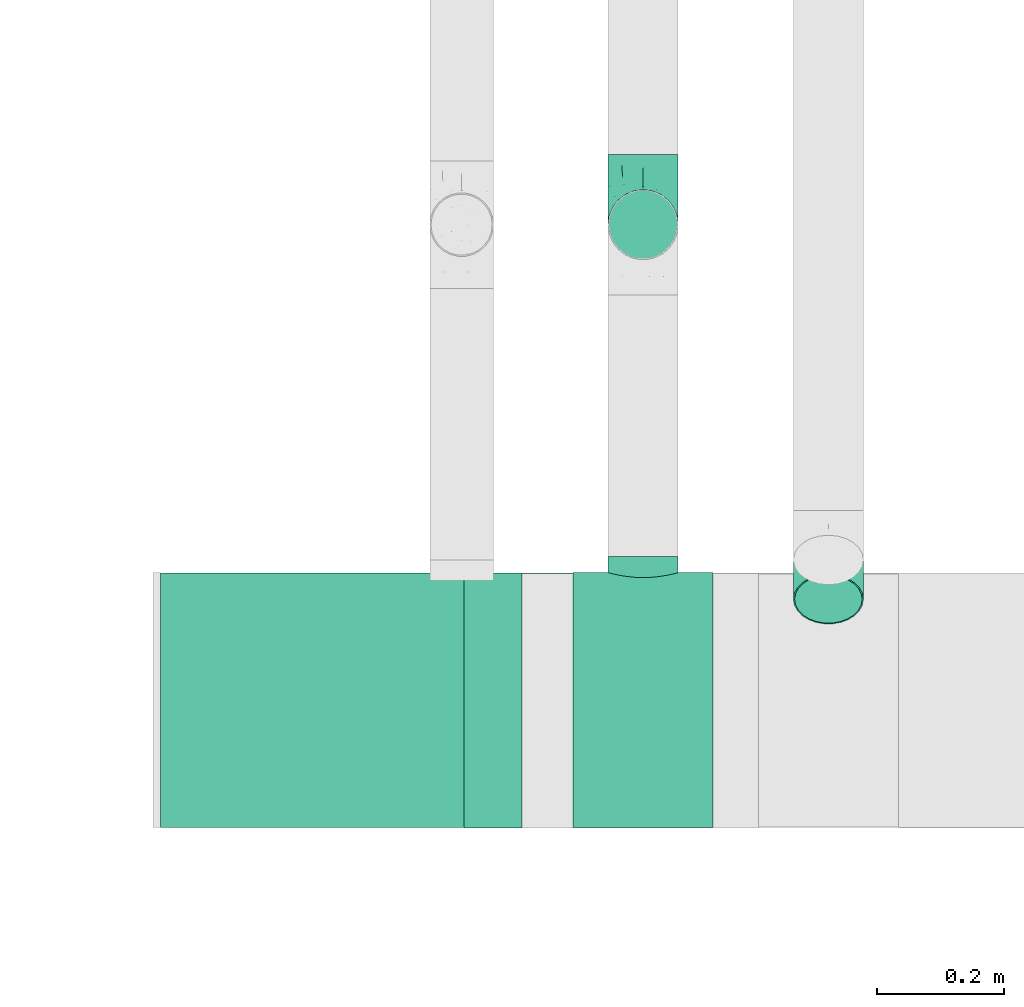
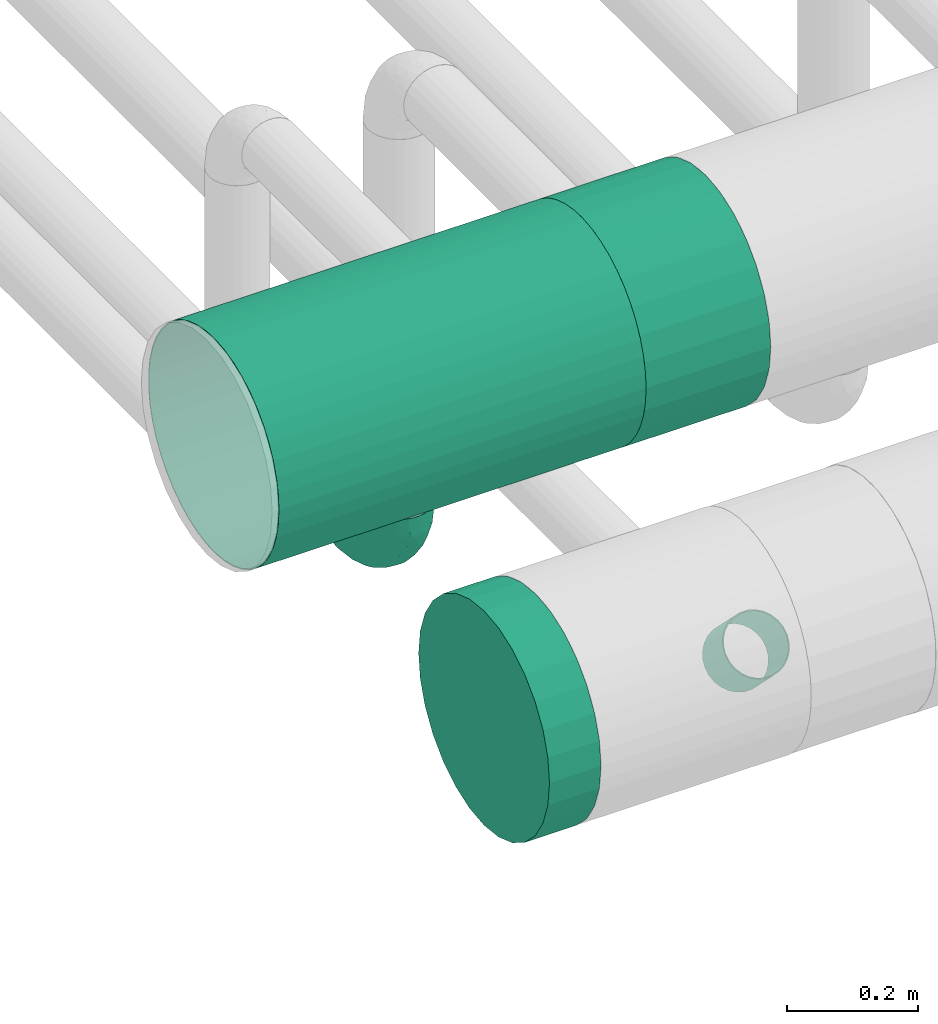
# One storey, part 73 of 91: 3 flow fittings, 2 flow segments.
"""IFC2X3 building model written with IfcOpenShell, lengths in millimetres."""

from ifc_helpers import new_model, entity, si_unit, converted_unit, derived_unit, direction, frame, origin_with_axes, origin_2d_with_axis, place, context, subcontext, project, spatial, hollow_circle, extrude, open_shell, surface_model, source, transform, mapped, material, layer, layer_set, layer_usage, type_object, element, save


model = new_model("IFC2X3")

# Units and contexts
model_context = context("Model", 3, precision=1e-05, world=origin_with_axes(), true_north=direction((0.0, 1.0)))
body_context = subcontext(model_context, "Body", "Model", "MODEL_VIEW")
ifc_project = project(units=[si_unit("AREAUNIT", "SQUARE_METRE"), si_unit("VOLUMEUNIT", "CUBIC_METRE", prefix="DECI"), si_unit("TIMEUNIT", "SECOND"), si_unit("THERMODYNAMICTEMPERATUREUNIT", "DEGREE_CELSIUS"), si_unit("PRESSUREUNIT", "PASCAL"), si_unit("MASSUNIT", "GRAM", prefix="KILO"), si_unit("LENGTHUNIT", "METRE", prefix="MILLI"), si_unit("POWERUNIT", "WATT"), si_unit("ELECTRICCURRENTUNIT", "AMPERE"), si_unit("ELECTRICVOLTAGEUNIT", "VOLT"), derived_unit("VOLUMETRICFLOWRATEUNIT", [(si_unit("VOLUMEUNIT", "CUBIC_METRE", prefix="DECI"), 1), (si_unit("TIMEUNIT", "SECOND"), -1)]), derived_unit("LINEARVELOCITYUNIT", [(si_unit("LENGTHUNIT", "METRE"), 1), (si_unit("TIMEUNIT", "SECOND"), -1)]), derived_unit("MASSDENSITYUNIT", [(si_unit("MASSUNIT", "GRAM", prefix="KILO"), 1), (si_unit("VOLUMEUNIT", "CUBIC_METRE"), -1)]), converted_unit("PLANEANGLEUNIT", "DEGREE", entity("IfcRatioMeasure", 0.01745), si_unit("PLANEANGLEUNIT", "RADIAN"), dimensions=[0, 0, 0, 0, 0, 0, 0])], contexts=[model_context])

# Site, building, storey
site_placement = place(None, origin_with_axes())
site = spatial("IfcSite", under=ifc_project, at=site_placement, CompositionType="ELEMENT")
building_placement = place(site_placement, origin_with_axes())
building = spatial("IfcBuilding", under=site, at=building_placement, Name="mc-building", CompositionType="ELEMENT")
storey_placement = place(building_placement, frame((0.0, 0.0, 8700.0), z_axis=(0.0, 0.0, 1.0), x_axis=(1.0, 0.0, 0.0)))
storey = spatial("IfcBuildingStorey", under=building, at=storey_placement, CompositionType="ELEMENT", Elevation=8700.0)

# Flow fittings
duct_fitting_type_1 = type_object("IfcDuctFittingType", PredefinedType="JUNCTION")
shared_shape_1 = source(origin_with_axes(), body_context, "Body", "SurfaceModel", [
    surface_model("IfcShellBasedSurfaceModel", [(0.0, -225.0, -55.0), (14.23505, -225.0, -53.12592), (-14.23505, -225.0, -53.12592), (-53.12592, -225.0, 14.23505), (-27.5, -225.0, -47.63139), (-47.63139, -225.0, -27.5), (-38.89087, -225.0, -38.89087), (55.0, -225.0, 0.0), (53.12592, -225.0, 14.23505), (38.89087, -225.0, -38.89087), (27.5, -225.0, -47.63139), (53.12592, -225.0, -14.23505), (47.63139, -225.0, -27.5), (-53.12592, -225.0, -14.23505), (-47.63139, -225.0, 27.5), (-38.89087, -225.0, 38.89087), (14.23505, -225.0, 53.12592), (-27.5, -225.0, 47.63139), (-14.23505, -225.0, 53.12592), (47.63139, -225.0, 27.5), (38.89087, -225.0, 38.89087), (27.5, -225.0, 47.63139), (0.0, -225.0, 55.0), (-55.0, -225.0, 0.0), (0.0, -192.28884, 55.0), (-12.29394, -192.68144, 53.60839), (-23.92751, -193.77184, 49.52246), (-34.31923, -195.32745, 42.97895), (-42.9874, -197.03532, 34.30865), (-49.52973, -198.56533, 23.91246), (-53.61252, -199.6229, 12.27592), (-55.0, -200.0, 0.0), (-49.52091, -198.56313, -23.93071), (-42.97449, -197.0325, -34.32482), (-53.60826, -199.62175, -12.29447), (-34.30293, -195.32458, -42.99196), (-23.90904, -193.76957, -49.53138), (-12.27509, -192.68024, -53.61271), (0.0, -192.28884, -55.0), (12.29394, -192.68144, -53.60839), (23.92751, -193.77184, -49.52246), (34.31923, -195.32745, -42.97895), (42.9874, -197.03532, -34.30865), (49.52973, -198.56533, -23.91246), (53.61252, -199.6229, -12.27592), (55.0, -200.0, 0.0), (49.52973, -198.56533, 23.91246), (42.9874, -197.03532, 34.30865), (53.61252, -199.6229, 12.27592), (34.31923, -195.32745, 42.97895), (23.92751, -193.77184, 49.52246), (12.29394, -192.68144, 53.60839), (-110.0, 0.0, -200.0), (-110.0, -44.50419, -194.98559), (-110.0, 44.50419, -194.98559), (-110.0, 194.98559, 44.50419), (-110.0, 86.77674, -180.19378), (-110.0, 180.19378, -86.77674), (-110.0, 156.36629, -124.69796), (-110.0, 124.69796, -156.36629), (-110.0, -200.0, 0.0), (-110.0, -194.98559, 44.50419), (-110.0, -124.69796, -156.36629), (-110.0, -86.77674, -180.19378), (-110.0, -156.36629, -124.69796), (-110.0, -180.19378, -86.77674), (-110.0, -194.98559, -44.50419), (-110.0, 194.98559, -44.50419), (-110.0, 180.19378, 86.77674), (-110.0, 156.36629, 124.69796), (-110.0, 86.77674, 180.19378), (-110.0, 124.69796, 156.36629), (-110.0, 44.50419, 194.98559), (-110.0, 0.0, 200.0), (-110.0, -156.36629, 124.69796), (-110.0, -180.19378, 86.77674), (-110.0, -86.77674, 180.19378), (-110.0, -44.50419, 194.98559), (-110.0, -124.69796, 156.36629), (-110.0, 200.0, 0.0), (110.0, 0.0, -200.0), (110.0, 44.50419, -194.98559), (110.0, 86.77674, -180.19378), (110.0, 200.0, 0.0), (110.0, 156.36629, -124.69796), (110.0, 180.19378, -86.77674), (110.0, 124.69796, -156.36629), (110.0, -156.36629, -124.69796), (110.0, -194.98559, 44.50419), (110.0, -86.77674, -180.19378), (110.0, -44.50419, -194.98559), (110.0, -124.69796, -156.36629), (110.0, -180.19378, -86.77674), (110.0, -194.98559, -44.50419), (110.0, -200.0, 0.0), (110.0, 194.98559, -44.50419), (110.0, 194.98559, 44.50419), (110.0, 180.19378, 86.77674), (110.0, 156.36629, 124.69796), (110.0, 124.69796, 156.36629), (110.0, 86.77674, 180.19378), (110.0, 44.50419, 194.98559), (110.0, -156.36629, 124.69796), (110.0, -180.19378, 86.77674), (110.0, -124.69796, 156.36629), (110.0, -86.77674, 180.19378), (110.0, -44.50419, 194.98559), (110.0, 0.0, 200.0), (-110.0, -197.4928, -22.25209), (110.0, -197.4928, -22.25209), (110.0, -197.4928, 22.25209), (-110.0, -197.4928, 22.25209)], [open_shell([[[0, 1, 2]], [[2, 3, 4]], [[5, 6, 3]], [[6, 4, 3]], [[2, 7, 8]], [[9, 7, 10]], [[1, 10, 7]], [[11, 7, 12]], [[9, 12, 7]], [[7, 2, 1]], [[5, 3, 13]], [[2, 14, 3]], [[2, 15, 14]], [[2, 16, 17]], [[17, 15, 2]], [[16, 18, 17]], [[2, 8, 19]], [[2, 19, 20]], [[2, 20, 21]], [[16, 2, 21]], [[16, 22, 18]], [[23, 13, 3]], [[22, 24, 25]], [[18, 25, 26]], [[22, 25, 18]], [[17, 27, 15]], [[17, 18, 26]], [[27, 17, 26]], [[28, 29, 14]], [[30, 31, 23]], [[29, 30, 3]], [[15, 28, 14]], [[3, 14, 29]], [[23, 3, 30]], [[28, 15, 27]], [[32, 33, 5]], [[34, 32, 13]], [[31, 34, 23]], [[23, 34, 13]], [[32, 5, 13]], [[33, 6, 5]], [[4, 35, 36]], [[36, 37, 2]], [[38, 0, 37]], [[4, 6, 35]], [[2, 4, 36]], [[37, 0, 2]], [[35, 6, 33]], [[0, 38, 39]], [[1, 39, 40]], [[0, 39, 1]], [[10, 41, 9]], [[10, 1, 40]], [[41, 10, 40]], [[42, 43, 12]], [[44, 45, 7]], [[43, 44, 11]], [[9, 42, 12]], [[11, 12, 43]], [[7, 11, 44]], [[42, 9, 41]], [[46, 47, 19]], [[48, 46, 8]], [[45, 48, 7]], [[7, 48, 8]], [[46, 19, 8]], [[47, 20, 19]], [[21, 49, 50]], [[50, 51, 16]], [[24, 22, 51]], [[20, 49, 21]], [[16, 21, 50]], [[22, 16, 51]], [[49, 20, 47]], [[52, 53, 54]], [[54, 55, 56]], [[55, 57, 58]], [[58, 59, 55]], [[59, 56, 55]], [[54, 60, 61]], [[62, 60, 63]], [[54, 53, 63]], [[60, 64, 65]], [[65, 66, 60]], [[60, 62, 64]], [[63, 60, 54]], [[55, 67, 57]], [[54, 68, 55]], [[54, 69, 68]], [[70, 71, 69]], [[70, 54, 72]], [[70, 69, 54]], [[72, 54, 73]], [[74, 73, 75]], [[54, 61, 75]], [[76, 77, 73]], [[73, 78, 76]], [[74, 78, 73]], [[54, 75, 73]], [[79, 67, 55]], [[80, 81, 82]], [[83, 80, 82]], [[84, 85, 83]], [[83, 86, 84]], [[83, 82, 86]], [[87, 80, 88]], [[80, 89, 90]], [[80, 91, 89]], [[91, 80, 87]], [[87, 88, 92]], [[93, 92, 88]], [[93, 88, 94]], [[85, 95, 83]], [[83, 96, 97]], [[98, 80, 97]], [[98, 99, 100]], [[80, 100, 101]], [[80, 98, 100]], [[80, 101, 102]], [[102, 103, 80]], [[88, 80, 103]], [[104, 102, 101]], [[104, 101, 105]], [[101, 106, 105]], [[101, 107, 106]], [[83, 97, 80]], [[72, 107, 101]], [[70, 101, 100]], [[71, 100, 99]], [[73, 107, 72]], [[72, 101, 70]], [[100, 71, 70]], [[99, 69, 71]], [[68, 98, 97]], [[55, 97, 96]], [[79, 96, 83]], [[69, 98, 68]], [[68, 97, 55]], [[96, 79, 55]], [[98, 69, 99]], [[83, 95, 79]], [[85, 84, 58]], [[95, 85, 67]], [[67, 79, 95]], [[58, 57, 85]], [[67, 85, 57]], [[84, 59, 58]], [[56, 86, 82]], [[54, 82, 81]], [[52, 81, 80]], [[59, 86, 56]], [[56, 82, 54]], [[81, 52, 54]], [[86, 59, 84]], [[90, 53, 80]], [[89, 63, 90]], [[65, 87, 92]], [[89, 91, 62]], [[87, 64, 91]], [[92, 40, 39]], [[39, 38, 92]], [[53, 90, 63]], [[62, 63, 89]], [[53, 52, 80]], [[38, 37, 65]], [[34, 108, 32]], [[64, 87, 65]], [[37, 36, 65]], [[64, 62, 91]], [[38, 65, 92]], [[42, 109, 43]], [[93, 42, 41]], [[93, 109, 42]], [[41, 40, 93]], [[93, 40, 92]], [[94, 45, 44]], [[43, 109, 44]], [[44, 109, 94]], [[36, 35, 66]], [[33, 32, 108]], [[33, 66, 35]], [[36, 66, 65]], [[34, 60, 108]], [[31, 60, 34]], [[108, 66, 33]], [[45, 94, 48]], [[94, 110, 48]], [[110, 47, 46]], [[47, 110, 88]], [[49, 47, 88]], [[29, 111, 30]], [[60, 31, 30]], [[111, 60, 30]], [[27, 26, 61]], [[61, 111, 28]], [[61, 28, 27]], [[26, 75, 61]], [[49, 88, 50]], [[51, 103, 24]], [[48, 110, 46]], [[51, 50, 103]], [[74, 103, 102]], [[103, 50, 88]], [[105, 106, 77]], [[76, 104, 105]], [[78, 102, 104]], [[73, 106, 107]], [[25, 24, 75]], [[28, 111, 29]], [[75, 24, 103]], [[74, 75, 103]], [[25, 75, 26]], [[102, 78, 74]], [[104, 76, 78]], [[77, 76, 105]], [[106, 73, 77]]])]),
])
flow_fitting_1_placement = place(storey_placement, frame((29597.94843, 10080.96985, 1344.0), z_axis=(0.0, 0.0, 1.0), x_axis=(-1.0, 0.0, 0.0)))
element("IfcFlowFitting", 1, at=flow_fitting_1_placement, inside=storey, type_object=duct_fitting_type_1, context=body_context, shape_type="MappedRepresentation", body=[
    mapped(shared_shape_1, transform((0.0, 0.0, 0.0), scale=1.0)),
])
duct_fitting_type_2 = type_object("IfcDuctFittingType", Name="BU", PredefinedType="BEND")
shared_shape_2 = source(origin_with_axes(), body_context, "Body", "SurfaceModel", [
    surface_model("IfcShellBasedSurfaceModel", [(-110.0, 0.0, -55.0), (-110.0, -14.23505, -53.12592), (-110.0, 14.23505, -53.12592), (-110.0, 53.12592, 14.23505), (-110.0, 27.5, -47.63139), (-110.0, 38.89087, -38.89087), (-110.0, -55.0, 0.0), (-110.0, -53.12592, 14.23505), (-110.0, -38.89087, -38.89087), (-110.0, -27.5, -47.63139), (-110.0, -53.12592, -14.23505), (-110.0, -47.63139, -27.5), (-110.0, -14.23505, 53.12592), (-110.0, 14.23505, 53.12592), (-110.0, 27.5, 47.63139), (-110.0, -47.63139, 27.5), (-110.0, -38.89087, 38.89087), (-110.0, -27.5, 47.63139), (-110.0, 0.0, 55.0), (-110.0, 55.0, 0.0), (-110.0, 53.12592, -14.23505), (-110.0, 47.63139, -27.5), (-110.0, 47.63139, 27.5), (-110.0, 38.89087, 38.89087), (-14.23505, 110.0, -53.12592), (-55.0, 110.0, 0.0), (0.0, 110.0, -55.0), (-27.5, 110.0, -47.63139), (-38.89087, 110.0, -38.89087), (-47.63139, 110.0, -27.5), (38.89087, 110.0, -38.89087), (53.12592, 110.0, 14.23505), (27.5, 110.0, -47.63139), (14.23505, 110.0, -53.12592), (47.63139, 110.0, -27.5), (53.12592, 110.0, -14.23505), (55.0, 110.0, 0.0), (-53.12592, 110.0, -14.23505), (-53.12592, 110.0, 14.23505), (-47.63139, 110.0, 27.5), (-38.89087, 110.0, 38.89087), (-27.5, 110.0, 47.63139), (0.0, 110.0, 55.0), (-14.23505, 110.0, 53.12592), (38.89087, 110.0, 38.89087), (47.63139, 110.0, 27.5), (27.5, 110.0, 47.63139), (14.23505, 110.0, 53.12592), (-64.21732, 48.68956, 43.63444), (-76.6405, 38.18013, 45.55988), (-60.44912, 32.56953, 51.94617), (-76.00813, 5.38378, 55.0), (-90.15553, 11.94394, 54.09138), (-78.5998, 26.77405, 50.81338), (-70.18771, 18.55163, 54.03432), (-75.55424, 54.2118, 32.41257), (-93.27622, 45.77614, 33.48188), (-96.12334, 22.13664, 50.81337), (-21.00813, 45.34362, 55.0), (-18.36258, 70.48427, 54.04484), (-32.04182, 59.64019, 52.24446), (-63.88653, 74.77858, 17.99134), (-74.66383, 63.08407, 19.92123), (-63.60674, 66.07878, 29.97482), (-99.597, 52.72185, 18.52927), (-93.11138, 56.59448, 10.50359), (-98.21577, 57.34403, 0.0), (-53.42855, 92.60092, 21.04759), (-88.54852, 54.8376, 21.04759), (-11.86161, 90.23965, 54.10313), (-5.38378, 76.00813, 55.0), (-57.34403, 98.21577, 0.0), (-56.64619, 93.12774, 10.22088), (-45.34362, 21.00813, 55.0), (-44.60838, 44.60838, 52.13415), (-92.68484, 35.46673, 43.63443), (-22.25266, 95.40765, 50.81337), (-35.97783, 90.61597, 43.63443), (-43.70931, 69.58671, 44.47149), (-27.23711, 77.39884, 50.81337), (-57.2828, 79.3123, 24.9774), (-58.67786, 84.31125, 16.04456), (-82.93277, 60.36161, 12.91784), (-49.88337, 54.51816, 47.224), (-74.57753, 66.83759, 9.55742), (-45.35812, 94.97281, 33.48188), (-59.18663, 88.95241, 0.0), (-51.517, 78.6292, 33.48188), (-65.14788, 80.03077, 0.0), (-56.45322, 62.06476, 39.63545), (-88.95241, 59.18663, 0.0), (-71.10913, 71.10913, 0.0), (-80.03077, 65.14788, 0.0), (-94.9309, 45.36788, -33.48188), (-93.11358, 56.60141, -10.46614), (-99.64997, 52.79499, -18.30015), (-90.20425, 36.08686, -43.63443), (-79.99933, 46.56772, -37.92748), (-76.00813, 5.38378, -55.0), (-72.75364, 19.68651, -53.60527), (-45.34362, 21.00813, -55.0), (-21.91957, 65.12078, -53.85897), (-5.38378, 76.00813, -55.0), (-21.00813, 45.34362, -55.0), (-35.41876, 92.89265, -43.63443), (-91.10309, 11.02766, -54.21832), (-45.77614, 93.27622, -33.48188), (-90.50474, 23.21022, -50.81337), (-70.92854, 33.31794, -49.51754), (-78.52933, 63.35627, -11.73997), (-24.91508, 84.05606, -50.81337), (-88.78941, 54.74452, -21.04759), (-69.59921, 57.34866, -33.48187), (-73.36422, 62.46673, -22.94182), (-63.49062, 67.59111, -28.46929), (-56.59448, 93.11138, -10.50359), (-54.8376, 88.54852, -21.04759), (-54.10679, 75.85581, -32.31867), (-57.75956, 31.09612, -52.80882), (-52.72185, 99.597, -18.52927), (-12.62913, 89.46304, -53.99097), (-34.46825, 66.46123, -50.04329), (-43.9837, 43.9837, -52.42279), (-65.78527, 72.58348, -17.68796), (-70.34468, 43.65295, -44.21951), (-57.47001, 51.99467, -44.91465), (-60.72547, 82.29174, -12.88567), (-42.34915, 74.24548, -43.63444), (-57.25194, 63.5016, -38.08211), (-80.95344, 53.56991, -29.32027), (-52.32891, 4.55257, -54.0482), (32.52942, 47.13398, -30.48571), (14.88266, 20.92917, -33.7947), (14.95561, 36.05775, -42.26543), (30.24048, 70.09027, -41.7461), (19.3559, 65.35825, -48.00507), (-70.35075, -46.44478, -19.5952), (-47.13398, -32.52942, -30.48571), (-28.49299, -30.5778, -16.4009), (-4.55257, 52.32891, -54.0482), (-22.4954, 22.4954, -53.25347), (-75.47368, -11.22546, -52.60718), (-81.32209, -51.5606, -9.98467), (-80.81763, -41.84862, -32.14655), (-70.09027, -30.24048, -41.7461), (-36.05774, -14.95561, -42.26543), (-9.15831, -10.852, -27.8997), (-65.35825, -19.3559, -48.00507), (11.22546, 75.47368, -52.60718), (3.94376, 43.9333, -50.53315), (-13.39742, 13.39743, -48.13058), (-43.9333, -3.94376, -50.53315), (49.37776, 67.29486, 0.0), (41.8609, 47.82256, -9.92641), (50.20582, 74.51695, -9.9731), (18.93131, 11.7156, -17.56239), (-27.5, -32.89419, 0.0), (-1.23348, -12.25375, -12.18106), (41.84862, 80.81763, -32.14655), (35.70604, 41.31408, -20.38235), (46.44478, 70.35075, -19.5952), (32.89419, 27.5, 0.0), (6.67262, -6.67262, 0.0), (-67.29486, -49.37776, 0.0), (-50.36265, -42.95545, -9.51562), (-5.47251, 5.47251, -39.92906), (-70.35075, -46.44478, 19.5952), (-74.51695, -50.20582, 9.9731), (-41.31407, -35.70604, 20.38235), (-47.13398, -32.52942, 30.48571), (-80.81763, -41.84862, 32.14655), (-4.55257, 52.32891, 54.0482), (11.22546, 75.47368, 52.60718), (-43.9333, -3.94376, 50.53315), (-65.35825, -19.3559, 48.00507), (-36.05774, -14.95561, 42.26543), (-70.09027, -30.24048, 41.7461), (-11.7156, -18.93131, 17.56239), (30.5778, 28.49299, 16.4009), (12.25375, 1.23348, 12.18106), (51.5606, 81.32209, 9.98467), (42.95545, 50.36265, 9.51562), (-75.47368, -11.22546, 52.60718), (-52.32891, 4.55257, 54.0482), (3.94376, 43.9333, 50.53315), (-22.4954, 22.4954, 53.25347), (-13.39742, 13.39743, 48.13058), (10.852, 9.15831, 27.8997), (-20.92916, -14.88266, 33.79469), (-47.82256, -41.8609, 9.92641), (32.52942, 47.13398, 30.48571), (46.44478, 70.35075, 19.5952), (41.84862, 80.81763, 32.14655), (30.24048, 70.09027, 41.7461), (19.3559, 65.35825, 48.00507), (14.95561, 36.05775, 42.26543), (-5.47251, 5.47251, 39.92906)], [open_shell([[[0, 1, 2]], [[2, 3, 4]], [[4, 3, 5]], [[2, 6, 7]], [[8, 6, 9]], [[1, 9, 6]], [[10, 6, 11]], [[8, 11, 6]], [[6, 2, 1]], [[12, 13, 14]], [[15, 2, 7]], [[16, 17, 2]], [[2, 17, 12]], [[12, 18, 13]], [[19, 20, 3]], [[5, 3, 21]], [[20, 21, 3]], [[22, 3, 2]], [[23, 22, 2]], [[12, 14, 2]], [[2, 14, 23]], [[15, 16, 2]], [[24, 25, 26]], [[27, 25, 24]], [[25, 28, 29]], [[28, 25, 27]], [[30, 26, 31]], [[26, 30, 32]], [[32, 33, 26]], [[34, 31, 35]], [[31, 34, 30]], [[35, 31, 36]], [[29, 37, 25]], [[38, 39, 26]], [[39, 40, 26]], [[41, 42, 40]], [[42, 26, 40]], [[42, 41, 43]], [[26, 44, 45]], [[31, 26, 45]], [[26, 46, 44]], [[47, 46, 26]], [[42, 47, 26]], [[25, 38, 26]], [[48, 49, 50]], [[18, 51, 52]], [[53, 54, 50]], [[55, 56, 49]], [[56, 22, 23]], [[13, 57, 14]], [[58, 59, 60]], [[61, 62, 63]], [[3, 64, 65]], [[53, 52, 54]], [[3, 65, 66]], [[67, 39, 38]], [[56, 68, 64]], [[65, 64, 68]], [[69, 59, 70]], [[38, 71, 72]], [[73, 58, 74]], [[75, 49, 56]], [[76, 69, 43]], [[53, 57, 52]], [[77, 78, 79]], [[41, 76, 43]], [[43, 69, 42]], [[55, 68, 56]], [[23, 14, 75]], [[76, 77, 79]], [[80, 67, 81]], [[62, 82, 68]], [[60, 78, 83]], [[62, 84, 82]], [[85, 77, 40]], [[81, 67, 72]], [[86, 72, 71]], [[87, 85, 67]], [[61, 81, 88]], [[77, 41, 40]], [[78, 77, 87]], [[23, 75, 56]], [[83, 89, 48]], [[85, 40, 39]], [[62, 68, 55]], [[89, 87, 63]], [[83, 48, 50]], [[57, 75, 14]], [[49, 75, 53]], [[67, 85, 39]], [[87, 77, 85]], [[63, 62, 55]], [[89, 55, 48]], [[80, 63, 87]], [[66, 65, 90]], [[66, 19, 3]], [[84, 91, 92]], [[92, 90, 82]], [[65, 82, 90]], [[61, 84, 62]], [[92, 82, 84]], [[68, 82, 65]], [[3, 22, 64]], [[56, 64, 22]], [[38, 25, 71]], [[81, 72, 86]], [[38, 72, 67]], [[91, 61, 88]], [[80, 81, 61]], [[63, 80, 61]], [[67, 80, 87]], [[77, 76, 41]], [[79, 59, 69]], [[79, 69, 76]], [[42, 69, 70]], [[60, 59, 79]], [[58, 70, 59]], [[78, 60, 79]], [[58, 60, 74]], [[52, 57, 13]], [[75, 57, 53]], [[18, 52, 13]], [[52, 51, 54]], [[51, 73, 54]], [[50, 73, 74]], [[73, 50, 54]], [[50, 74, 83]], [[60, 83, 74]], [[89, 83, 78]], [[87, 89, 78]], [[55, 89, 63]], [[50, 49, 53]], [[55, 49, 48]], [[81, 86, 88]], [[91, 84, 61]], [[5, 21, 93]], [[90, 94, 66]], [[20, 94, 95]], [[96, 93, 97]], [[98, 99, 100]], [[96, 4, 5]], [[101, 102, 103]], [[28, 27, 104]], [[2, 105, 0]], [[104, 106, 28]], [[99, 105, 107]], [[108, 107, 96]], [[90, 109, 94]], [[107, 2, 4]], [[20, 66, 94]], [[27, 24, 110]], [[109, 111, 94]], [[112, 113, 114]], [[37, 115, 71]], [[116, 106, 117]], [[99, 118, 100]], [[116, 115, 119]], [[37, 119, 115]], [[24, 120, 110]], [[121, 110, 101]], [[119, 106, 116]], [[101, 110, 120]], [[122, 103, 100]], [[117, 123, 116]], [[124, 125, 108]], [[115, 116, 126]], [[106, 29, 28]], [[26, 102, 120]], [[127, 104, 110]], [[97, 124, 96]], [[125, 122, 118]], [[128, 127, 125]], [[96, 5, 93]], [[115, 126, 86]], [[117, 106, 127]], [[111, 113, 129]], [[95, 93, 21]], [[97, 129, 112]], [[110, 104, 27]], [[106, 104, 127]], [[96, 107, 4]], [[99, 107, 108]], [[99, 108, 118]], [[105, 99, 98]], [[112, 114, 128]], [[121, 125, 127]], [[20, 19, 66]], [[109, 90, 92]], [[94, 111, 95]], [[91, 123, 109]], [[129, 113, 112]], [[93, 95, 111]], [[21, 20, 95]], [[71, 115, 86]], [[71, 25, 37]], [[123, 91, 88]], [[126, 116, 123]], [[123, 88, 126]], [[86, 126, 88]], [[37, 29, 119]], [[106, 119, 29]], [[129, 93, 111]], [[124, 112, 125]], [[0, 105, 98]], [[107, 105, 2]], [[125, 118, 108]], [[100, 118, 122]], [[93, 129, 97]], [[113, 111, 109]], [[109, 123, 113]], [[114, 123, 117]], [[123, 114, 113]], [[128, 114, 117]], [[127, 128, 117]], [[112, 128, 125]], [[103, 122, 101]], [[110, 121, 127]], [[101, 122, 121]], [[125, 121, 122]], [[26, 120, 24]], [[101, 120, 102]], [[96, 124, 108]], [[92, 91, 109]], [[112, 124, 97]], [[100, 130, 98]], [[131, 132, 133]], [[32, 134, 135]], [[136, 137, 138]], [[139, 140, 103]], [[98, 141, 0]], [[142, 10, 136]], [[143, 144, 137]], [[6, 10, 142]], [[137, 145, 146]], [[144, 147, 145]], [[143, 136, 11]], [[11, 136, 10]], [[8, 143, 11]], [[148, 149, 139]], [[8, 9, 144]], [[9, 1, 147]], [[130, 141, 98]], [[103, 140, 100]], [[148, 135, 149]], [[150, 151, 140]], [[152, 153, 154]], [[130, 140, 151]], [[148, 26, 33]], [[147, 1, 141]], [[155, 146, 132]], [[156, 138, 157]], [[134, 30, 158]], [[150, 140, 149]], [[158, 30, 34]], [[30, 134, 32]], [[153, 159, 160]], [[131, 160, 159]], [[144, 145, 137]], [[36, 152, 154]], [[146, 138, 137]], [[155, 161, 162]], [[158, 160, 131]], [[133, 149, 135]], [[156, 163, 164]], [[163, 142, 164]], [[139, 103, 102]], [[153, 152, 161]], [[34, 35, 160]], [[162, 157, 155]], [[132, 165, 133]], [[157, 146, 155]], [[140, 130, 100]], [[141, 130, 151]], [[141, 151, 147]], [[141, 1, 0]], [[102, 26, 148]], [[140, 139, 149]], [[102, 148, 139]], [[135, 33, 32]], [[151, 150, 145]], [[9, 147, 144]], [[151, 145, 147]], [[145, 165, 146]], [[135, 148, 33]], [[133, 135, 134]], [[131, 133, 134]], [[133, 165, 150]], [[133, 150, 149]], [[145, 150, 165]], [[132, 131, 159]], [[146, 165, 132]], [[160, 158, 34]], [[134, 158, 131]], [[144, 143, 8]], [[136, 143, 137]], [[155, 153, 161]], [[154, 153, 160]], [[153, 155, 159]], [[132, 159, 155]], [[160, 35, 154]], [[36, 154, 35]], [[164, 136, 138]], [[6, 142, 163]], [[136, 164, 142]], [[156, 164, 138]], [[156, 157, 162]], [[146, 157, 138]], [[15, 7, 166]], [[6, 163, 167]], [[168, 169, 166]], [[166, 169, 170]], [[171, 172, 70]], [[173, 174, 175]], [[17, 176, 174]], [[177, 156, 162]], [[176, 16, 170]], [[170, 16, 15]], [[161, 178, 179]], [[152, 180, 181]], [[182, 173, 183]], [[18, 12, 182]], [[184, 185, 186]], [[183, 185, 73]], [[183, 73, 51]], [[177, 187, 188]], [[189, 168, 166]], [[187, 178, 190]], [[16, 176, 17]], [[161, 152, 181]], [[45, 191, 31]], [[45, 44, 192]], [[192, 191, 45]], [[180, 36, 31]], [[193, 194, 195]], [[46, 47, 194]], [[193, 195, 190]], [[193, 44, 46]], [[172, 42, 70]], [[185, 58, 73]], [[189, 163, 156]], [[163, 189, 167]], [[70, 58, 171]], [[184, 171, 185]], [[169, 188, 175]], [[180, 31, 191]], [[192, 193, 190]], [[191, 190, 178]], [[182, 174, 173]], [[194, 47, 172]], [[190, 195, 187]], [[186, 185, 173]], [[162, 179, 177]], [[188, 196, 175]], [[179, 187, 177]], [[185, 171, 58]], [[172, 171, 184]], [[172, 184, 194]], [[172, 47, 42]], [[51, 18, 182]], [[185, 183, 173]], [[51, 182, 183]], [[174, 12, 17]], [[184, 186, 195]], [[46, 194, 193]], [[184, 195, 194]], [[195, 196, 187]], [[174, 182, 12]], [[175, 174, 176]], [[169, 175, 176]], [[175, 196, 186]], [[175, 186, 173]], [[195, 186, 196]], [[188, 169, 168]], [[187, 196, 188]], [[166, 170, 15]], [[176, 170, 169]], [[193, 192, 44]], [[191, 192, 190]], [[177, 189, 156]], [[167, 189, 166]], [[189, 177, 168]], [[188, 168, 177]], [[166, 7, 167]], [[6, 167, 7]], [[181, 191, 178]], [[36, 180, 152]], [[191, 181, 180]], [[161, 181, 178]], [[161, 179, 162]], [[187, 179, 178]]])]),
])
flow_fitting_2_placement = place(storey_placement, frame((29597.94843, 10827.25695, 415.0), z_axis=(-1.0, 0.0, 0.0), x_axis=(0.0, -1.0, 0.0)))
element("IfcFlowFitting", 2, at=flow_fitting_2_placement, inside=storey, type_object=duct_fitting_type_2, Name="BU", context=body_context, shape_type="MappedRepresentation", body=[
    mapped(shared_shape_2, transform((0.0, 0.0, 0.0), scale=1.0)),
])
duct_fitting_type_3 = type_object("IfcDuctFittingType", Name="EPF", PredefinedType="OBSTRUCTION")
shared_shape_3 = source(origin_with_axes(), body_context, "Body", "SurfaceModel", [
    surface_model("IfcShellBasedSurfaceModel", [(0.0, 86.77674, -180.19378), (0.0, 44.50419, -194.98559), (0.0, 0.0, -200.0), (0.0, 124.69796, -156.36629), (0.0, 180.19378, -86.77674), (0.0, 194.98559, -44.50419), (0.0, 156.36629, -124.69796), (0.0, 0.0, 200.0), (0.0, -194.98559, -44.50419), (0.0, -86.77674, -180.19378), (0.0, -124.69796, -156.36629), (0.0, -44.50419, -194.98559), (0.0, -180.19378, -86.77674), (0.0, -156.36629, -124.69796), (0.0, -200.0, 0.0), (0.0, -194.98559, 44.50419), (0.0, 200.0, 0.0), (0.0, 180.19378, 86.77674), (0.0, 194.98559, 44.50419), (0.0, 156.36629, 124.69796), (0.0, 86.77674, 180.19378), (0.0, 124.69796, 156.36629), (0.0, 44.50419, 194.98559), (0.0, -180.19378, 86.77674), (0.0, -156.36629, 124.69796), (0.0, -86.77674, 180.19378), (0.0, -44.50419, 194.98559), (0.0, -124.69796, 156.36629), (91.0, 44.50419, -194.98559), (91.0, -44.50419, -194.98559), (91.0, 0.0, -200.0), (91.0, 86.77674, -180.19378), (91.0, 156.36629, -124.69796), (91.0, 180.19378, -86.77674), (91.0, 124.69796, -156.36629), (91.0, 194.98559, -44.50419), (91.0, -124.69796, -156.36629), (91.0, -86.77674, -180.19378), (91.0, -194.98559, -44.50419), (91.0, -156.36629, -124.69796), (91.0, -180.19378, -86.77674), (91.0, -200.0, 0.0), (91.0, 44.50419, 194.98559), (91.0, 86.77674, 180.19378), (91.0, 194.98559, 44.50419), (91.0, 180.19378, 86.77674), (91.0, 156.36629, 124.69796), (91.0, 124.69796, 156.36629), (91.0, -44.50419, 194.98559), (91.0, -180.19378, 86.77674), (91.0, -194.98559, 44.50419), (91.0, -156.36629, 124.69796), (91.0, -124.69796, 156.36629), (91.0, -86.77674, 180.19378), (91.0, 0.0, 200.0), (91.0, 200.0, 0.0)], [open_shell([[[0, 1, 2]], [[3, 0, 2]], [[4, 2, 5]], [[6, 2, 4]], [[6, 3, 2]], [[7, 2, 8]], [[9, 10, 11]], [[8, 11, 10]], [[12, 10, 13]], [[8, 10, 12]], [[11, 8, 2]], [[14, 15, 8]], [[5, 2, 16]], [[17, 18, 16]], [[19, 17, 16]], [[16, 20, 21]], [[22, 20, 2]], [[21, 19, 16]], [[2, 7, 22]], [[23, 24, 8]], [[8, 15, 23]], [[25, 26, 7]], [[25, 8, 27]], [[8, 24, 27]], [[8, 25, 7]], [[2, 20, 16]], [[28, 29, 30]], [[31, 29, 28]], [[32, 33, 29]], [[32, 29, 34]], [[29, 31, 34]], [[29, 33, 35]], [[29, 36, 37]], [[36, 29, 38]], [[39, 36, 40]], [[38, 40, 36]], [[41, 38, 29]], [[41, 29, 42]], [[29, 35, 43]], [[44, 45, 35]], [[35, 45, 46]], [[47, 43, 35]], [[42, 29, 43]], [[46, 47, 35]], [[48, 41, 42]], [[41, 49, 50]], [[51, 49, 41]], [[41, 52, 51]], [[41, 53, 52]], [[53, 41, 48]], [[42, 54, 48]], [[55, 44, 35]], [[7, 54, 42]], [[43, 47, 20]], [[20, 42, 43]], [[7, 42, 22]], [[21, 20, 47]], [[42, 20, 22]], [[47, 19, 21]], [[17, 46, 45]], [[18, 45, 44]], [[16, 44, 55]], [[19, 46, 17]], [[17, 45, 18]], [[44, 16, 18]], [[46, 19, 47]], [[16, 55, 35]], [[35, 33, 5]], [[32, 4, 33]], [[16, 35, 5]], [[4, 5, 33]], [[6, 4, 32]], [[32, 34, 6]], [[0, 34, 31]], [[1, 31, 28]], [[2, 28, 30]], [[3, 34, 0]], [[0, 31, 1]], [[28, 2, 1]], [[34, 3, 6]], [[2, 30, 29]], [[11, 29, 37]], [[10, 37, 36]], [[2, 29, 11]], [[9, 11, 37]], [[10, 9, 37]], [[36, 39, 10]], [[12, 39, 40]], [[8, 40, 38]], [[14, 38, 41]], [[13, 39, 12]], [[12, 40, 8]], [[38, 14, 8]], [[39, 13, 10]], [[14, 41, 50]], [[49, 51, 24]], [[15, 50, 49]], [[14, 50, 15]], [[24, 23, 49]], [[49, 23, 15]], [[51, 27, 24]], [[25, 52, 53]], [[26, 53, 48]], [[7, 48, 54]], [[27, 52, 25]], [[25, 53, 26]], [[48, 7, 26]], [[52, 27, 51]]])]),
])
flow_fitting_3_placement = place(storey_placement, frame((29407.94843, 10080.05037, 668.0), z_axis=(0.0, 0.0, 1.0), x_axis=(-1.0, 0.0, 0.0)))
element("IfcFlowFitting", 3, at=flow_fitting_3_placement, inside=storey, type_object=duct_fitting_type_3, context=body_context, shape_type="MappedRepresentation", body=[
    mapped(shared_shape_3, transform((0.0, 0.0, 0.0), scale=1.0)),
])

# Flow segments
ifc_material = material(Name="FZ1")
ifc_layer = layer(ifc_material, 0.0)
ifc_layer_set = layer_set([ifc_layer], Name="FZ1")
ifc_layer_usage = layer_usage(ifc_layer_set, "AXIS1", "POSITIVE", 0.0)
duct_segment_type_1 = type_object("IfcDuctSegmentType", PredefinedType="RIGIDSEGMENT")
shared_shape_4 = source(origin_with_axes(), body_context, "Body", "SweptSolid", [
    extrude(hollow_circle(Radius=55.0, WallThickness=2.0, at=origin_2d_with_axis()), frame((0.0, 0.0, 0.0), z_axis=(1.0, 0.0, 0.0), x_axis=(0.0, 1.0, 0.0)), (0.0, 0.0, 1.0), 87.2),
])
flow_segment_1_placement = place(storey_placement, frame((29888.82784, 10239.14939, 508.90097), z_axis=(0.0, -0.707107, -0.707107), x_axis=(0.0, 0.707107, -0.707107)))
element("IfcFlowSegment", 4, at=flow_segment_1_placement, inside=storey, type_object=duct_segment_type_1, material=ifc_layer_usage, context=body_context, shape_type="MappedRepresentation", body=[
    mapped(shared_shape_4, transform((0.0, 0.0, 0.0), scale=1.0)),
])
duct_segment_type_2 = type_object("IfcDuctSegmentType", Name="Safe", PredefinedType="RIGIDSEGMENT")
shared_shape_5 = source(origin_with_axes(), body_context, "Body", "SweptSolid", [
    extrude(hollow_circle(Radius=200.0, WallThickness=2.0, at=origin_2d_with_axis()), frame((0.0, 0.0, 0.0), z_axis=(1.0, 0.0, 0.0), x_axis=(0.0, 1.0, 0.0)), (0.0, 0.0, 1.0), 647.7),
])
flow_segment_2_placement = place(storey_placement, frame((29487.94843, 10080.96985, 1344.0), z_axis=(0.0, 0.0, 1.0), x_axis=(-1.0, 0.0, 0.0)))
element("IfcFlowSegment", 5, at=flow_segment_2_placement, inside=storey, type_object=duct_segment_type_2, material=ifc_layer_usage, Name="Safe", context=body_context, shape_type="MappedRepresentation", body=[
    mapped(shared_shape_5, transform((0.0, 0.0, 0.0), scale=1.0)),
])

save(model, "model.ifc")
